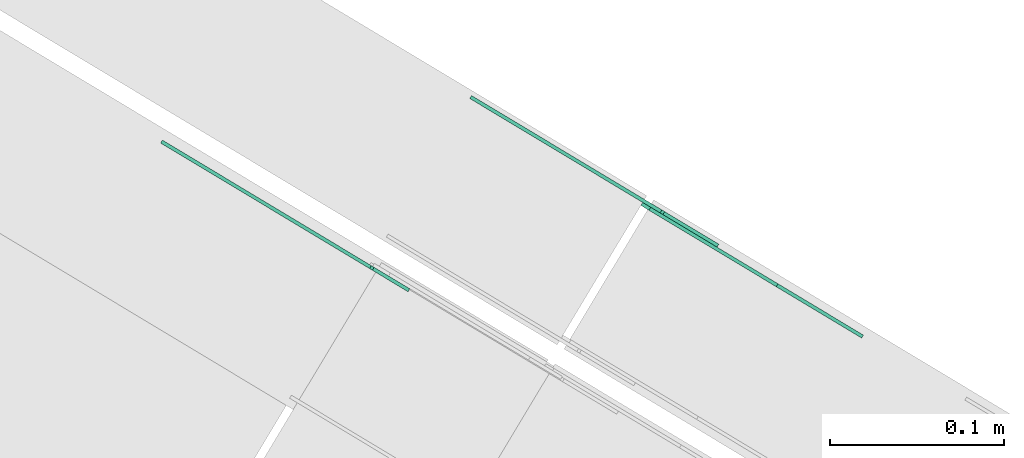
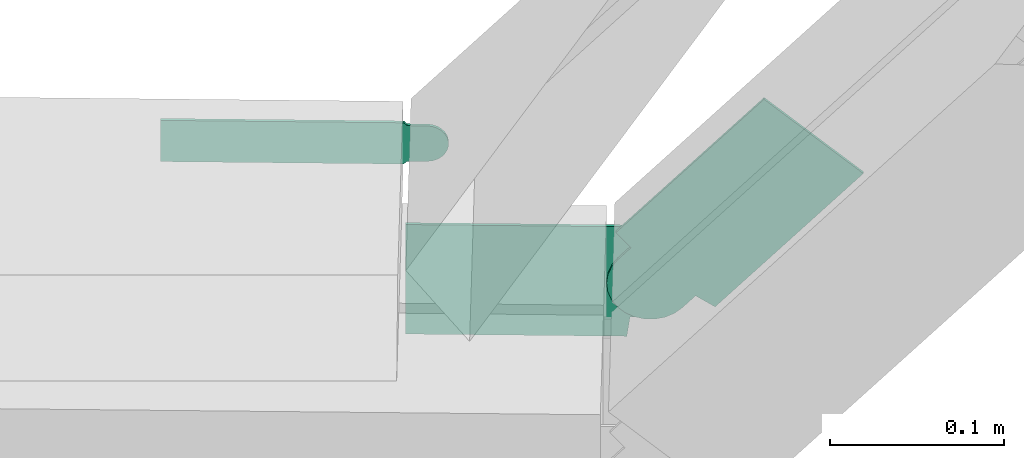
# One storey, part 5 of 28: 3 flow fittings.
"""IFC2X3 building model written with IfcOpenShell, lengths in millimetres."""

from ifc_helpers import new_model, entity, si_unit, converted_unit, derived_unit, direction, frame, frame_2d, origin, place, context, subcontext, project, spatial, polyline, circle_curve, parameter, trimmed, segment, composite_curve, outline, extrude, source, transform, mapped, material, type_object, type_shapes, element, save


model = new_model("IFC2X3")

# Units and contexts
model_context = context("Model", 3, precision=0.01, world=origin(), true_north=direction((6.12303176911189e-17, 1.0)))
body_context = subcontext(model_context, "Body", "Model", "MODEL_VIEW")
ifc_project = project(units=[si_unit("LENGTHUNIT", "METRE", prefix="MILLI"), si_unit("AREAUNIT", "SQUARE_METRE"), si_unit("VOLUMEUNIT", "CUBIC_METRE"), converted_unit("PLANEANGLEUNIT", "DEGREE", entity("IfcRatioMeasure", 0.0174532925199433), si_unit("PLANEANGLEUNIT", "RADIAN"), dimensions=[0, 0, 0, 0, 0, 0, 0]), si_unit("MASSUNIT", "GRAM", prefix="KILO"), derived_unit("MASSDENSITYUNIT", [(si_unit("MASSUNIT", "GRAM", prefix="KILO"), 1), (si_unit("LENGTHUNIT", "METRE"), -3)]), derived_unit("MOMENTOFINERTIAUNIT", [(si_unit("LENGTHUNIT", "METRE"), 4)]), si_unit("TIMEUNIT", "SECOND"), si_unit("FREQUENCYUNIT", "HERTZ"), si_unit("THERMODYNAMICTEMPERATUREUNIT", "DEGREE_CELSIUS"), derived_unit("THERMALTRANSMITTANCEUNIT", [(si_unit("MASSUNIT", "GRAM", prefix="KILO"), 1), (si_unit("THERMODYNAMICTEMPERATUREUNIT", "KELVIN"), -1), (si_unit("TIMEUNIT", "SECOND"), -3)]), derived_unit("VOLUMETRICFLOWRATEUNIT", [(si_unit("LENGTHUNIT", "METRE"), 3), (si_unit("TIMEUNIT", "SECOND"), -1)]), derived_unit("MASSFLOWRATEUNIT", [(si_unit("MASSUNIT", "GRAM", prefix="KILO"), 1), (si_unit("TIMEUNIT", "SECOND"), -1)]), derived_unit("ROTATIONALFREQUENCYUNIT", [(si_unit("TIMEUNIT", "SECOND"), -1)]), si_unit("ELECTRICCURRENTUNIT", "AMPERE"), si_unit("ELECTRICVOLTAGEUNIT", "VOLT"), si_unit("POWERUNIT", "WATT"), si_unit("FORCEUNIT", "NEWTON", prefix="KILO"), si_unit("ILLUMINANCEUNIT", "LUX"), si_unit("LUMINOUSFLUXUNIT", "LUMEN"), si_unit("LUMINOUSINTENSITYUNIT", "CANDELA"), derived_unit("USERDEFINED", [(si_unit("MASSUNIT", "GRAM", prefix="KILO"), -1), (si_unit("LENGTHUNIT", "METRE"), -2), (si_unit("TIMEUNIT", "SECOND"), 3), (si_unit("LUMINOUSFLUXUNIT", "LUMEN"), 1)]), derived_unit("LINEARVELOCITYUNIT", [(si_unit("LENGTHUNIT", "METRE"), 1), (si_unit("TIMEUNIT", "SECOND"), -1)]), si_unit("PRESSUREUNIT", "PASCAL"), derived_unit("USERDEFINED", [(si_unit("LENGTHUNIT", "METRE"), -2), (si_unit("MASSUNIT", "GRAM", prefix="KILO"), 1), (si_unit("TIMEUNIT", "SECOND"), -2)]), derived_unit("LINEARFORCEUNIT", [(si_unit("MASSUNIT", "GRAM", prefix="KILO"), 1), (si_unit("LENGTHUNIT", "METRE"), 1), (si_unit("TIMEUNIT", "SECOND"), -2), (si_unit("LENGTHUNIT", "METRE"), -1)]), derived_unit("PLANARFORCEUNIT", [(si_unit("MASSUNIT", "GRAM", prefix="KILO"), 1), (si_unit("LENGTHUNIT", "METRE"), 1), (si_unit("TIMEUNIT", "SECOND"), -2), (si_unit("LENGTHUNIT", "METRE"), -2)])], contexts=[model_context])

# Site, building, storey
site_placement = place(None, frame((0.0, -0.00077364408347762, 0.0)))
site = spatial("IfcSite", under=ifc_project, at=site_placement, CompositionType="ELEMENT")
building_placement = place(site_placement, origin())
building = spatial("IfcBuilding", under=site, at=building_placement, CompositionType="ELEMENT")
storey_placement = place(building_placement, origin())
storey = spatial("IfcBuildingStorey", under=building, at=storey_placement, CompositionType="ELEMENT", Elevation=0.0)

# Flow fittings
ifc_material = material(Name="G")
cable_carrier_fitting_type_1 = type_object("IfcCableCarrierFittingType", PredefinedType="NOTDEFINED", material=ifc_material)
shared_shape_1 = source(origin(), body_context, "Body", "SweptSolid", [
    extrude(outline(composite_curve([segment(trimmed(circle_curve(frame_2d((-44.5901162790698, 0.0), x_axis=(1.0, 0.0)), 12.5), [parameter(90.0000000000007)], [parameter(270.0)], True, "PARAMETER"), True, "CONTINUOUS"), segment(polyline([(-44.5901162790697, -12.5), (-33.0901162790698, -12.5)]), True, "CONTINUOUS"), segment(polyline([(-33.0901162790698, -12.5), (-31.2296511627907, -14.5)]), True, "CONTINUOUS"), segment(polyline([(-31.2296511627907, -14.5), (108.90988372093, -14.5)]), True, "CONTINUOUS"), segment(polyline([(108.90988372093, -14.5), (108.90988372093, 14.5)]), True, "CONTINUOUS"), segment(polyline([(108.90988372093, 14.5), (-31.2296511627907, 14.5)]), True, "CONTINUOUS"), segment(polyline([(-31.2296511627907, 14.5), (-33.0901162790698, 12.5)]), True, "CONTINUOUS"), segment(polyline([(-33.0901162790698, 12.5), (-44.5901162790699, 12.5)]), True, "CONTINUOUS")], self_intersect=False)), frame((44.5901162790698, 0.0, 0.0), z_axis=(0.0, 0.0, -1.0), x_axis=(1.0, 0.0, 0.0)), (0.0, 0.0, -1.0), 2.0),
])
type_shapes(cable_carrier_fitting_type_1, [shared_shape_1])
flow_fitting_1_placement = place(storey_placement, frame((2202.98858026527, 12713.5054675368, 2825.0), z_axis=(0.515038074910046, 0.857167300702117, 0.0), x_axis=(-0.857167300702117, 0.515038074910046, 0.0)))
element("IfcFlowFitting", 1, at=flow_fitting_1_placement, inside=storey, type_object=cable_carrier_fitting_type_1, material=ifc_material, context=body_context, shape_type="MappedRepresentation", body=[
    mapped(shared_shape_1, transform((0.0, 0.0, 0.0), scale=1.0)),
])
cable_carrier_fitting_type_2 = type_object("IfcCableCarrierFittingType", PredefinedType="NOTDEFINED", material=ifc_material)
shared_shape_2 = source(origin(), body_context, "Body", "SweptSolid", [
    extrude(outline(composite_curve([segment(trimmed(circle_curve(frame_2d((-41.4651162790697, 0.0), x_axis=(1.0, 0.0)), 25.0), [parameter(90.0000000000007)], [parameter(270.0)], True, "PARAMETER"), True, "CONTINUOUS"), segment(polyline([(-41.4651162790697, -25.0), (-29.9651162790697, -25.0)]), True, "CONTINUOUS"), segment(polyline([(-29.9651162790697, -25.0), (-28.1046511627907, -38.5)]), True, "CONTINUOUS"), segment(polyline([(-28.1046511627907, -38.5), (99.5348837209303, -38.5)]), True, "CONTINUOUS"), segment(polyline([(99.5348837209303, -38.5), (99.5348837209303, 38.5)]), True, "CONTINUOUS"), segment(polyline([(99.5348837209303, 38.5), (-28.1046511627907, 38.5)]), True, "CONTINUOUS"), segment(polyline([(-28.1046511627907, 38.5), (-29.9651162790697, 25.0)]), True, "CONTINUOUS"), segment(polyline([(-29.9651162790697, 25.0), (-41.46511627907, 25.0)]), True, "CONTINUOUS")], self_intersect=False)), frame((41.4651162790697, 0.0, 0.0), z_axis=(0.0, 0.0, -1.0), x_axis=(1.0, 0.0, 0.0)), (0.0, 0.0, -1.0), 2.0),
])
type_shapes(cable_carrier_fitting_type_2, [shared_shape_2])
flow_fitting_2_placement = place(storey_placement, frame((2369.91953456615, 12745.5364977952, 2650.0), z_axis=(0.515038074910055, 0.857167300702112, 0.0), x_axis=(-0.857167300702112, 0.515038074910055, 0.0)))
element("IfcFlowFitting", 2, at=flow_fitting_2_placement, inside=storey, type_object=cable_carrier_fitting_type_2, material=ifc_material, context=body_context, shape_type="MappedRepresentation", body=[
    mapped(shared_shape_2, transform((0.0, 0.0, 0.0), scale=1.0)),
])
cable_carrier_fitting_type_3 = type_object("IfcCableCarrierFittingType", PredefinedType="NOTDEFINED", material=ifc_material)
shared_shape_3 = source(origin(), body_context, "Body", "SweptSolid", [
    extrude(outline(composite_curve([segment(trimmed(circle_curve(frame_2d((-41.4651162790697, 0.0), x_axis=(1.0, 0.0)), 25.0), [parameter(90.0000000000007)], [parameter(270.0)], True, "PARAMETER"), True, "CONTINUOUS"), segment(polyline([(-41.4651162790697, -25.0), (-29.9651162790697, -25.0)]), True, "CONTINUOUS"), segment(polyline([(-29.9651162790697, -25.0), (-28.1046511627907, -38.5)]), True, "CONTINUOUS"), segment(polyline([(-28.1046511627907, -38.5), (99.5348837209303, -38.5)]), True, "CONTINUOUS"), segment(polyline([(99.5348837209303, -38.5), (99.5348837209303, 38.5)]), True, "CONTINUOUS"), segment(polyline([(99.5348837209303, 38.5), (-28.1046511627907, 38.5)]), True, "CONTINUOUS"), segment(polyline([(-28.1046511627907, 38.5), (-29.9651162790697, 25.0)]), True, "CONTINUOUS"), segment(polyline([(-29.9651162790697, 25.0), (-41.46511627907, 25.0)]), True, "CONTINUOUS")], self_intersect=False)), frame((41.4651162790697, 0.0, 0.0)), (0.0, 0.0, 1.0), 2.0),
])
type_shapes(cable_carrier_fitting_type_3, [shared_shape_3])
flow_fitting_3_placement = place(storey_placement, frame((2368.88945841633, 12743.8221631938, 2650.0), z_axis=(0.515038074910072, 0.857167300702102, 0.0), x_axis=(0.573556875669665, -0.344627739362432, 0.743144825477505)))
element("IfcFlowFitting", 3, at=flow_fitting_3_placement, inside=storey, type_object=cable_carrier_fitting_type_3, material=ifc_material, context=body_context, shape_type="MappedRepresentation", body=[
    mapped(shared_shape_3, transform((0.0, 0.0, 0.0), scale=1.0)),
])

save(model, "model.ifc")
